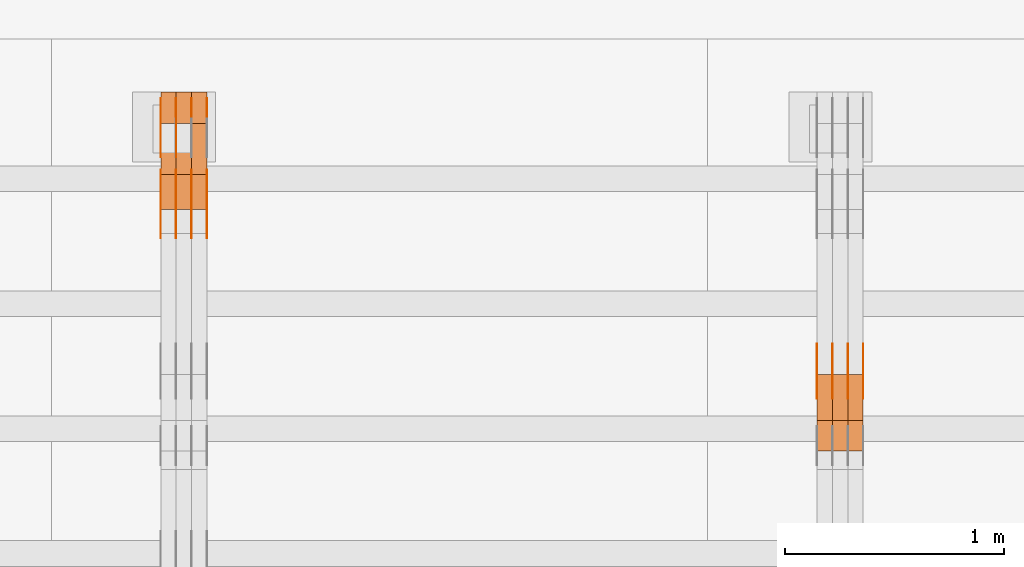
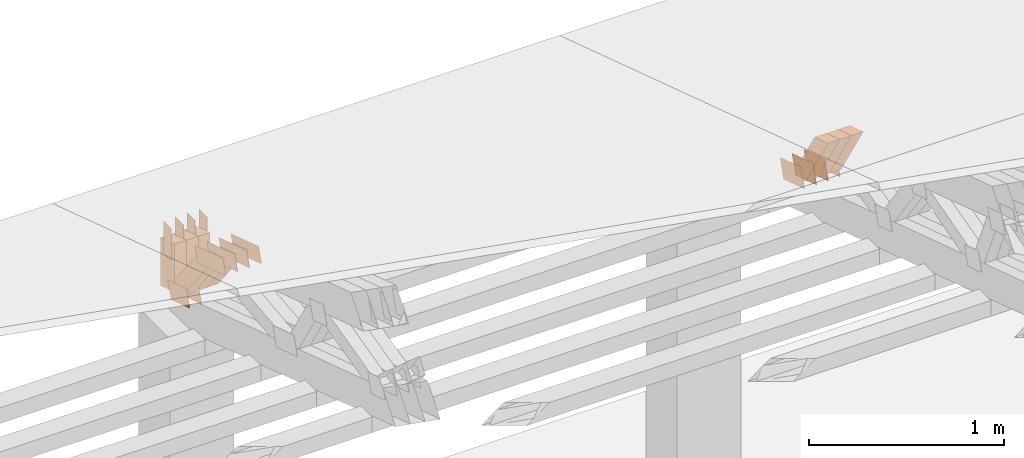
# One storey, part 238 of 385: 29 proxies.
"""IFC2X3 building model written with IfcOpenShell, lengths in millimetres."""

import ifcopenshell
import ifcopenshell.guid

model = None  # the IFC model being written
_history = None  # IfcOwnerHistory: only IFC2X3 demands one
_inside = {}  # id of a spatial element -> (the spatial element, [elements in it])
_under = {}  # id of a project, library or spatial element -> (it, [spatial elements below it])
_declared = {}  # id of a project -> (the project, [libraries it declares])
_typed = {}  # id of a type object -> (the type object, [elements of that type])
_made_of = {}  # id of a material, layer set ... -> (it, [elements and type objects made of it])


def new_model(schema):
    """Start an empty IFC model of exactly this schema.

    Asked for "IFC4X3", IfcOpenShell would pick the latest addendum, in which some entities
    have other attributes; the version numbers below select the first issue.
    IFC2X3 requires an IfcOwnerHistory on every rooted entity: one is made here for all.
    """
    global model, _history
    if schema == "IFC4X3":
        model = ifcopenshell.file(schema_version=(4, 3, 0, 0))
    else:
        model = ifcopenshell.file(schema=schema)
    _inside.clear()
    _under.clear()
    _declared.clear()
    _typed.clear()
    _made_of.clear()
    _history = None
    if model.schema == "IFC2X3":
        org = make("IfcOrganization", Name="unknown")
        user = make(
            "IfcPersonAndOrganization",
            ThePerson=make("IfcPerson", FamilyName="unknown"),
            TheOrganization=org,
        )
        app = make(
            "IfcApplication",
            ApplicationDeveloper=org,
            Version="unknown",
            ApplicationFullName="unknown",
            ApplicationIdentifier="unknown",
        )
        _history = make(
            "IfcOwnerHistory",
            OwningUser=user,
            OwningApplication=app,
            ChangeAction="ADDED",
            CreationDate=0,
        )
    return model


def make(cls, **values):
    """One entity of the class cls with the attributes given. An attribute that is None is left unset."""
    return model.create_entity(
        cls, **{name: value for name, value in values.items() if value is not None}
    )


def entity(cls, *values):
    """Any entity or typed value of the class cls, its attributes in the order of the schema. None: left unset."""
    e = model.create_entity(cls)
    for i, value in enumerate(values):
        if value is not None:
            e[i] = value
    return e


def rooted(cls, **values):
    """An entity with a GlobalId (a new one), such as an element, a storey or a relation."""
    return make(cls, GlobalId=ifcopenshell.guid.new(), OwnerHistory=_history, **values)


def si_unit(unit_type, name, prefix=None):
    """IfcSIUnit, for example si_unit("LENGTHUNIT", "METRE", prefix="MILLI")."""
    return make("IfcSIUnit", UnitType=unit_type, Prefix=prefix, Name=name)


def converted_unit(unit_type, name, factor, base, dimensions=None, offset=None):
    """IfcConversionBasedUnit, such as the inch: factor (a typed value) times the base unit."""
    return make(
        "IfcConversionBasedUnit"
        if offset is None
        else "IfcConversionBasedUnitWithOffset",
        ConversionOffset=offset,
        Dimensions=None
        if dimensions is None
        else entity("IfcDimensionalExponents", *dimensions),
        UnitType=unit_type,
        Name=name,
        ConversionFactor=make(
            "IfcMeasureWithUnit", ValueComponent=factor, UnitComponent=base
        ),
    )


def derived_unit(unit_type, elements):
    """IfcDerivedUnit: a product of units, each with its exponent."""
    return make(
        "IfcDerivedUnit",
        Elements=[
            make("IfcDerivedUnitElement", Unit=unit, Exponent=power)
            for unit, power in elements
        ],
        UnitType=unit_type,
    )


def assignment(units):
    """IfcUnitAssignment: the units of a project."""
    return None if units is None else make("IfcUnitAssignment", Units=units)


def point(xyz):
    """IfcCartesianPoint."""
    return None if xyz is None else make("IfcCartesianPoint", Coordinates=xyz)


def direction(xyz):
    """IfcDirection."""
    return None if xyz is None else make("IfcDirection", DirectionRatios=xyz)


def frame(location, z_axis=None, x_axis=None):
    """IfcAxis2Placement3D, a coordinate frame: its origin and axes. An axis left out is left unset."""
    return make(
        "IfcAxis2Placement3D",
        Location=point(location),
        Axis=direction(z_axis),
        RefDirection=direction(x_axis),
    )


def frame_2d(location, x_axis=None):
    """IfcAxis2Placement2D, a coordinate frame in the plane: its origin and x axis."""
    return make(
        "IfcAxis2Placement2D", Location=point(location), RefDirection=direction(x_axis)
    )


def origin():
    """The frame at (0, 0, 0) with its axes left unset."""
    return frame((0.0, 0.0, 0.0))


def place(relative_to, where):
    """IfcLocalPlacement: puts the frame where relative to a parent placement (None: the world)."""
    return make(
        "IfcLocalPlacement", PlacementRelTo=relative_to, RelativePlacement=where
    )


def context(
    kind, dimensions, precision=None, world=None, true_north=None, identifier=None
):
    """IfcGeometricRepresentationContext, for example the 3D "Model" context."""
    return make(
        "IfcGeometricRepresentationContext",
        ContextIdentifier=identifier,
        ContextType=kind,
        CoordinateSpaceDimension=dimensions,
        Precision=precision,
        WorldCoordinateSystem=world,
        TrueNorth=true_north,
    )


def subcontext(parent, identifier, kind, view, scale=None):
    """IfcGeometricRepresentationSubContext, for example "Body" below "Model"."""
    return make(
        "IfcGeometricRepresentationSubContext",
        ContextIdentifier=identifier,
        ContextType=kind,
        ParentContext=parent,
        TargetScale=scale,
        TargetView=view,
    )


def project(units=None, contexts=None):
    """IfcProject with its units and contexts."""
    return rooted(
        "IfcProject",
        Name="project",
        RepresentationContexts=contexts,
        UnitsInContext=assignment(units),
    )


def spatial(cls, under=None, at=None, **own):
    """A site, building, storey or space (cls), placed at a placement, below another one or the project."""
    s = rooted(cls, ObjectPlacement=at, **own)
    if under is not None:
        _under.setdefault(under.id(), (under, []))[1].append(s)
    return s


def polyline(points):
    """IfcPolyline through the points."""
    return make("IfcPolyline", Points=[point(p) for p in points])


def profile(cls, at=None, kind="AREA", **sizes):
    """A parametric profile (cls). Its sizes go by their IFC names, for example OverallWidth=200.0."""
    return make(cls, ProfileType=kind, Position=at, **sizes)


def rectangle(**sizes):
    """IfcRectangleProfileDef."""
    return profile("IfcRectangleProfileDef", **sizes)


def outline(outer, holes=None, kind="AREA"):
    """IfcArbitraryClosedProfileDef: a profile drawn as a closed curve; with holes, ...WithVoids."""
    if holes is None:
        return make("IfcArbitraryClosedProfileDef", ProfileType=kind, OuterCurve=outer)
    return make(
        "IfcArbitraryProfileDefWithVoids",
        ProfileType=kind,
        OuterCurve=outer,
        InnerCurves=holes,
    )


def extrude(swept, where, along, depth):
    """IfcExtrudedAreaSolid: the profile swept, set in the frame where, extruded along a direction by depth."""
    return make(
        "IfcExtrudedAreaSolid",
        SweptArea=swept,
        Position=where,
        ExtrudedDirection=direction(along),
        Depth=depth,
    )


def shape(context_of_items, identifier, shape_type, items):
    """IfcShapeRepresentation: the items that make up one representation, for example the "Body"."""
    return make(
        "IfcShapeRepresentation",
        ContextOfItems=context_of_items,
        RepresentationIdentifier=identifier,
        RepresentationType=shape_type,
        Items=items,
    )


def source(mapping_origin, context_of_items, identifier, shape_type, items):
    """IfcRepresentationMap: a shape defined once, which mapped items show again and again."""
    return make(
        "IfcRepresentationMap",
        MappingOrigin=mapping_origin,
        MappedRepresentation=shape(context_of_items, identifier, shape_type, items),
    )


def transform(
    local_origin,
    x_axis=None,
    y_axis=None,
    z_axis=None,
    scale=None,
    scale2=None,
    scale3=None,
    uniform=True,
):
    """IfcCartesianTransformationOperator3D, or its non-uniform kind. x_axis, y_axis, z_axis: its Axis1, 2, 3."""
    if uniform:
        return make(
            "IfcCartesianTransformationOperator3D",
            Axis1=direction(x_axis),
            Axis2=direction(y_axis),
            LocalOrigin=point(local_origin),
            Scale=scale,
            Axis3=direction(z_axis),
        )
    return make(
        "IfcCartesianTransformationOperator3DnonUniform",
        Axis1=direction(x_axis),
        Axis2=direction(y_axis),
        LocalOrigin=point(local_origin),
        Scale=scale,
        Axis3=direction(z_axis),
        Scale2=scale2,
        Scale3=scale3,
    )


def mapped(mapping_source, mapping_target):
    """IfcMappedItem: shows the shape of a source again, moved by a transform."""
    return make(
        "IfcMappedItem", MappingSource=mapping_source, MappingTarget=mapping_target
    )


def material(Name=None, Category=None):
    """IfcMaterial."""
    return make("IfcMaterial", Name=Name, Category=Category)


def made_of(thing, what):
    """Note that an element or type object is made of a material, layer set ...; save() writes the relation."""
    if what is not None:
        _made_of.setdefault(what.id(), (what, []))[1].append(thing)
    return thing


def type_object(cls, material=None, **own):
    """A type object (cls), such as IfcWallType, which elements share."""
    return made_of(rooted(cls, **own), material)


def type_shapes(of_type, sources):
    """Give a type object the sources (RepresentationMaps) that its elements show as mapped items."""
    of_type.RepresentationMaps = sources


def element(
    cls,
    number,
    at=None,
    inside=None,
    cuts=None,
    type_object=None,
    material=None,
    context=None,
    identifier="Body",
    shape_type=None,
    held_by="IfcProductDefinitionShape",
    body=None,
    shapes=None,
    **own,
):
    """One element of the class cls, such as IfcWall. Its Tag is "e" and its number.

    at: its placement. inside: the storey or other place that contains it. cuts: it is an
    opening in that element (IfcRelVoidsElement). A single representation is given by context,
    identifier, shape_type and body (its items); several are given by shapes. held_by: the class
    of the entity that holds the representations. save() writes the other relations.
    """
    e = rooted(cls, Tag="e%d" % number, ObjectPlacement=at, **own)
    if body is not None:
        shapes = [shape(context, identifier, shape_type, body)]
    if shapes is not None:
        e.Representation = make(held_by, Representations=shapes)
    if inside is not None:
        _inside.setdefault(inside.id(), (inside, []))[1].append(e)
    if cuts is not None:
        rooted(
            "IfcRelVoidsElement", RelatingBuildingElement=cuts, RelatedOpeningElement=e
        )
    if type_object is not None:
        _typed.setdefault(type_object.id(), (type_object, []))[1].append(e)
    return made_of(e, material)


def aggregate(whole, parts):
    """IfcRelAggregates: a whole, such as a stair, and the parts it consists of."""
    return rooted("IfcRelAggregates", RelatingObject=whole, RelatedObjects=parts)


def save(model, path):
    """Write the relations noted so far, then the file.

    IfcRelAggregates (storeys below a building ...), IfcRelContainedInSpatialStructure (elements
    in a storey), IfcRelDefinesByType, IfcRelAssociatesMaterial and IfcRelDeclares: one each for
    every whole, place, type object, material and project.
    """
    for whole, parts in _under.values():
        aggregate(whole, parts)
    for where, things in _inside.values():
        rooted(
            "IfcRelContainedInSpatialStructure",
            RelatedElements=things,
            RelatingStructure=where,
        )
    for kind, things in _typed.values():
        rooted("IfcRelDefinesByType", RelatedObjects=things, RelatingType=kind)
    for what, things in _made_of.values():
        rooted("IfcRelAssociatesMaterial", RelatedObjects=things, RelatingMaterial=what)
    for by, libraries in _declared.values():
        rooted("IfcRelDeclares", RelatingContext=by, RelatedDefinitions=libraries)
    model.write(path)


model = new_model("IFC2X3")

# Units and contexts
model_context = context("Model", 3, precision=0.01, world=origin(), true_north=direction((6.12303176911189e-17, 1.0)))
body_context = subcontext(model_context, "Body", "Model", "MODEL_VIEW")
ifc_project = project(units=[si_unit("LENGTHUNIT", "METRE", prefix="MILLI"), si_unit("AREAUNIT", "SQUARE_METRE"), si_unit("VOLUMEUNIT", "CUBIC_METRE"), converted_unit("PLANEANGLEUNIT", "DEGREE", entity("IfcRatioMeasure", 0.0174532925199433), si_unit("PLANEANGLEUNIT", "RADIAN"), dimensions=[0, 0, 0, 0, 0, 0, 0]), si_unit("MASSUNIT", "GRAM", prefix="KILO"), derived_unit("MASSDENSITYUNIT", [(si_unit("MASSUNIT", "GRAM", prefix="KILO"), 1), (si_unit("LENGTHUNIT", "METRE"), -3)]), si_unit("TIMEUNIT", "SECOND"), si_unit("FREQUENCYUNIT", "HERTZ"), si_unit("THERMODYNAMICTEMPERATUREUNIT", "DEGREE_CELSIUS"), derived_unit("THERMALTRANSMITTANCEUNIT", [(si_unit("MASSUNIT", "GRAM", prefix="KILO"), 1), (si_unit("THERMODYNAMICTEMPERATUREUNIT", "KELVIN"), -1), (si_unit("TIMEUNIT", "SECOND"), -3)]), derived_unit("VOLUMETRICFLOWRATEUNIT", [(si_unit("LENGTHUNIT", "METRE"), 3), (si_unit("TIMEUNIT", "SECOND"), -1)]), si_unit("ELECTRICCURRENTUNIT", "AMPERE"), si_unit("ELECTRICVOLTAGEUNIT", "VOLT"), si_unit("POWERUNIT", "WATT"), si_unit("FORCEUNIT", "NEWTON", prefix="KILO"), si_unit("ILLUMINANCEUNIT", "LUX"), si_unit("LUMINOUSFLUXUNIT", "LUMEN"), si_unit("LUMINOUSINTENSITYUNIT", "CANDELA"), derived_unit("USERDEFINED", [(si_unit("MASSUNIT", "GRAM", prefix="KILO"), -1), (si_unit("LENGTHUNIT", "METRE"), -2), (si_unit("TIMEUNIT", "SECOND"), 3), (si_unit("LUMINOUSFLUXUNIT", "LUMEN"), 1)]), derived_unit("LINEARVELOCITYUNIT", [(si_unit("LENGTHUNIT", "METRE"), 1), (si_unit("TIMEUNIT", "SECOND"), -1)]), si_unit("PRESSUREUNIT", "PASCAL"), derived_unit("USERDEFINED", [(si_unit("LENGTHUNIT", "METRE"), -2), (si_unit("MASSUNIT", "GRAM", prefix="KILO"), 1), (si_unit("TIMEUNIT", "SECOND"), -2)])], contexts=[model_context])

# Site, building, storey
site_placement = place(None, origin())
site = spatial("IfcSite", under=ifc_project, at=site_placement, CompositionType="ELEMENT")
building_placement = place(site_placement, origin())
building = spatial("IfcBuilding", under=site, at=building_placement, CompositionType="ELEMENT")
storey_placement = place(building_placement, origin())
storey = spatial("IfcBuildingStorey", under=building, at=storey_placement, Name="Default", CompositionType="ELEMENT", Elevation=0.0)

# Proxies
ifc_material_1 = material(Name="IfcSurfaceStyle #331820")
building_element_proxy_type_1 = type_object("IfcBuildingElementProxyType", PredefinedType="NOTDEFINED", material=ifc_material_1)
shared_shape_1 = source(origin(), body_context, "Body", "SweptSolid", [
    extrude(outline(polyline([(-112.50003853564, -60.0000121429077), (112.50002982902, -60.0000121429077), (112.500043250865, 60.0000121429077), (-112.500034544245, 60.0000121429077), (-112.50003853564, -60.0000121429077)])), frame((112.500056021398, 60.0000121429077, 0.0), z_axis=(0.0, 0.0, 1.0), x_axis=(-1.0, 0.0, 0.0)), (0.0, 0.0, 1.0), 1.3),
])
type_shapes(building_element_proxy_type_1, [shared_shape_1])
proxy_1_placement = place(building_placement, frame((27386.3, 25310.2182710495, 430.675738123044), z_axis=(-1.0, 0.0, 0.0), x_axis=(0.0, -0.951056516295124, 0.309016994375039)))
element("IfcBuildingElementProxy", 1, at=proxy_1_placement, inside=storey, type_object=building_element_proxy_type_1, material=ifc_material_1, context=body_context, shape_type="MappedRepresentation", body=[
    mapped(shared_shape_1, transform((0.0, 0.0, 0.0), scale=1.0)),
])
ifc_material_2 = material(Name="IfcSurfaceStyle #331763")
building_element_proxy_type_2 = type_object("IfcBuildingElementProxyType", PredefinedType="NOTDEFINED", material=ifc_material_2)
shared_shape_2 = source(origin(), body_context, "Body", "SweptSolid", [
    extrude(outline(polyline([(-112.50003853564, -60.0000121429077), (112.50002982902, -60.0000121429077), (112.500043250865, 60.0000121429077), (-112.500034544245, 60.0000121429077), (-112.50003853564, -60.0000121429077)])), frame((112.500056021398, 60.0000121429077, 0.0), z_axis=(0.0, 0.0, 1.0), x_axis=(-1.0, 0.0, 0.0)), (0.0, 0.0, 1.0), 1.3),
])
type_shapes(building_element_proxy_type_2, [shared_shape_2])
proxy_2_placement = place(building_placement, frame((27315.0, 25310.2182710495, 430.675738123044), z_axis=(-1.0, 0.0, 0.0), x_axis=(0.0, -0.951056516295124, 0.309016994375039)))
element("IfcBuildingElementProxy", 2, at=proxy_2_placement, inside=storey, type_object=building_element_proxy_type_2, material=ifc_material_2, context=body_context, shape_type="MappedRepresentation", body=[
    mapped(shared_shape_2, transform((0.0, 0.0, 0.0), scale=1.0)),
])
ifc_material_3 = material(Name="IfcSurfaceStyle #331706")
building_element_proxy_type_3 = type_object("IfcBuildingElementProxyType", PredefinedType="NOTDEFINED", material=ifc_material_3)
shared_shape_3 = source(origin(), body_context, "Body", "SweptSolid", [
    extrude(outline(polyline([(-112.50003853564, -60.0000121429077), (112.50002982902, -60.0000121429077), (112.500043250865, 60.0000121429077), (-112.500034544245, 60.0000121429077), (-112.50003853564, -60.0000121429077)])), frame((112.500056021398, 60.0000121429077, 0.0), z_axis=(0.0, 0.0, 1.0), x_axis=(-1.0, 0.0, 0.0)), (0.0, 0.0, 1.0), 1.3),
])
type_shapes(building_element_proxy_type_3, [shared_shape_3])
proxy_3_placement = place(building_placement, frame((27316.3, 25310.2182710495, 430.675738123044), z_axis=(-1.0, 0.0, 0.0), x_axis=(0.0, -0.951056516295124, 0.309016994375039)))
element("IfcBuildingElementProxy", 3, at=proxy_3_placement, inside=storey, type_object=building_element_proxy_type_3, material=ifc_material_3, context=body_context, shape_type="MappedRepresentation", body=[
    mapped(shared_shape_3, transform((0.0, 0.0, 0.0), scale=1.0)),
])
ifc_material_4 = material(Name="IfcSurfaceStyle #331649")
building_element_proxy_type_4 = type_object("IfcBuildingElementProxyType", PredefinedType="NOTDEFINED", material=ifc_material_4)
shared_shape_4 = source(origin(), body_context, "Body", "SweptSolid", [
    extrude(outline(polyline([(-112.50003853564, -60.0000121429077), (112.50002982902, -60.0000121429077), (112.500043250865, 60.0000121429077), (-112.500034544245, 60.0000121429077), (-112.50003853564, -60.0000121429077)])), frame((112.500056021398, 60.0000121429077, 0.0), z_axis=(0.0, 0.0, 1.0), x_axis=(-1.0, 0.0, 0.0)), (0.0, 0.0, 1.0), 1.29999999999998),
])
type_shapes(building_element_proxy_type_4, [shared_shape_4])
proxy_4_placement = place(building_placement, frame((27245.0, 25310.2182710495, 430.675738123044), z_axis=(-1.0, 0.0, 0.0), x_axis=(0.0, -0.951056516295124, 0.309016994375039)))
element("IfcBuildingElementProxy", 4, at=proxy_4_placement, inside=storey, type_object=building_element_proxy_type_4, material=ifc_material_4, context=body_context, shape_type="MappedRepresentation", body=[
    mapped(shared_shape_4, transform((0.0, 0.0, 0.0), scale=1.0)),
])
ifc_material_5 = material(Name="IfcSurfaceStyle #331592")
building_element_proxy_type_5 = type_object("IfcBuildingElementProxyType", PredefinedType="NOTDEFINED", material=ifc_material_5)
shared_shape_5 = source(origin(), body_context, "Body", "SweptSolid", [
    extrude(outline(polyline([(-112.50003853564, -60.0000121429077), (112.50002982902, -60.0000121429077), (112.500043250865, 60.0000121429077), (-112.500034544245, 60.0000121429077), (-112.50003853564, -60.0000121429077)])), frame((112.500056021398, 60.0000121429077, 0.0), z_axis=(0.0, 0.0, 1.0), x_axis=(-1.0, 0.0, 0.0)), (0.0, 0.0, 1.0), 1.29999999999998),
])
type_shapes(building_element_proxy_type_5, [shared_shape_5])
proxy_5_placement = place(building_placement, frame((27246.3, 25310.2182710495, 430.675738123044), z_axis=(-1.0, 0.0, 0.0), x_axis=(0.0, -0.951056516295124, 0.309016994375039)))
element("IfcBuildingElementProxy", 5, at=proxy_5_placement, inside=storey, type_object=building_element_proxy_type_5, material=ifc_material_5, context=body_context, shape_type="MappedRepresentation", body=[
    mapped(shared_shape_5, transform((0.0, 0.0, 0.0), scale=1.0)),
])
ifc_material_6 = material(Name="IfcSurfaceStyle #331535")
building_element_proxy_type_6 = type_object("IfcBuildingElementProxyType", PredefinedType="NOTDEFINED", material=ifc_material_6)
shared_shape_6 = source(origin(), body_context, "Body", "SweptSolid", [
    extrude(outline(polyline([(-112.50003853564, -60.0000121429077), (112.50002982902, -60.0000121429077), (112.500043250865, 60.0000121429077), (-112.500034544245, 60.0000121429077), (-112.50003853564, -60.0000121429077)])), frame((112.500056021398, 60.0000121429077, 0.0), z_axis=(0.0, 0.0, 1.0), x_axis=(-1.0, 0.0, 0.0)), (0.0, 0.0, 1.0), 1.29999999999999),
])
type_shapes(building_element_proxy_type_6, [shared_shape_6])
proxy_6_placement = place(building_placement, frame((27175.0, 25310.2182710495, 430.675738123044), z_axis=(-1.0, 0.0, 0.0), x_axis=(0.0, -0.951056516295124, 0.309016994375039)))
element("IfcBuildingElementProxy", 6, at=proxy_6_placement, inside=storey, type_object=building_element_proxy_type_6, material=ifc_material_6, context=body_context, shape_type="MappedRepresentation", body=[
    mapped(shared_shape_6, transform((0.0, 0.0, 0.0), scale=1.0)),
])
ifc_material_7 = material(Name="IfcSurfaceStyle #319778")
building_element_proxy_type_7 = type_object("IfcBuildingElementProxyType", Name="T1-W31 319776", PredefinedType="NOTDEFINED", material=ifc_material_7)
shared_shape_7 = source(origin(), body_context, "Body", "SweptSolid", [
    extrude(outline(polyline([(-201.245318299844, -47.5000121670808), (204.413774229459, -47.5000121670808), (182.034306640891, 5.35692244583164e-05), (126.70380769348, 47.4999853824686), (-311.906570263987, 47.4999853824686), (-201.245318299844, -47.5000121670808)])), frame((204.413774229459, 47.5002684334588, 0.0), z_axis=(0.0, 0.0, 1.0), x_axis=(-1.0, 0.0, 0.0)), (0.0, 0.0, 1.0), 70.0),
])
type_shapes(building_element_proxy_type_7, [shared_shape_7])
proxy_7_placement = place(building_placement, frame((27385.0, 25127.5652647985, 487.27008059185), z_axis=(-1.0, 0.0, 0.0), x_axis=(0.0, -0.520333970303023, 0.853962855953755)))
element("IfcBuildingElementProxy", 7, at=proxy_7_placement, inside=storey, type_object=building_element_proxy_type_7, material=ifc_material_7, Name="T1-W31", context=body_context, shape_type="MappedRepresentation", body=[
    mapped(shared_shape_7, transform((0.0, 0.0, 0.0), scale=1.0)),
])
ifc_material_8 = material(Name="IfcSurfaceStyle #319712")
building_element_proxy_type_8 = type_object("IfcBuildingElementProxyType", Name="T1-W31 319710", PredefinedType="NOTDEFINED", material=ifc_material_8)
shared_shape_8 = source(origin(), body_context, "Body", "SweptSolid", [
    extrude(outline(polyline([(-201.245318299844, -47.5000121670808), (204.413774229459, -47.5000121670808), (182.034306640891, 5.35692244583164e-05), (126.70380769348, 47.4999853824686), (-311.906570263987, 47.4999853824686), (-201.245318299844, -47.5000121670808)])), frame((204.413774229459, 47.5002684334588, 0.0), z_axis=(0.0, 0.0, 1.0), x_axis=(-1.0, 0.0, 0.0)), (0.0, 0.0, 1.0), 70.0),
])
type_shapes(building_element_proxy_type_8, [shared_shape_8])
proxy_8_placement = place(building_placement, frame((27315.0, 25127.5652647985, 487.27008059185), z_axis=(-1.0, 0.0, 0.0), x_axis=(0.0, -0.520333970303023, 0.853962855953755)))
element("IfcBuildingElementProxy", 8, at=proxy_8_placement, inside=storey, type_object=building_element_proxy_type_8, material=ifc_material_8, Name="T1-W31", context=body_context, shape_type="MappedRepresentation", body=[
    mapped(shared_shape_8, transform((0.0, 0.0, 0.0), scale=1.0)),
])
ifc_material_9 = material(Name="IfcSurfaceStyle #319646")
building_element_proxy_type_9 = type_object("IfcBuildingElementProxyType", Name="T1-W31 319644", PredefinedType="NOTDEFINED", material=ifc_material_9)
shared_shape_9 = source(origin(), body_context, "Body", "SweptSolid", [
    extrude(outline(polyline([(-201.245318299844, -47.5000121670808), (204.413774229459, -47.5000121670808), (182.034306640891, 5.35692244583164e-05), (126.70380769348, 47.4999853824686), (-311.906570263987, 47.4999853824686), (-201.245318299844, -47.5000121670808)])), frame((204.413774229459, 47.5002684334588, 0.0), z_axis=(0.0, 0.0, 1.0), x_axis=(-1.0, 0.0, 0.0)), (0.0, 0.0, 1.0), 70.0),
])
type_shapes(building_element_proxy_type_9, [shared_shape_9])
proxy_9_placement = place(building_placement, frame((27245.0, 25127.5652647985, 487.27008059185), z_axis=(-1.0, 0.0, 0.0), x_axis=(0.0, -0.520333970303023, 0.853962855953755)))
element("IfcBuildingElementProxy", 9, at=proxy_9_placement, inside=storey, type_object=building_element_proxy_type_9, material=ifc_material_9, Name="T1-W31", context=body_context, shape_type="MappedRepresentation", body=[
    mapped(shared_shape_9, transform((0.0, 0.0, 0.0), scale=1.0)),
])
ifc_material_10 = material(Name="IfcSurfaceStyle #309130")
building_element_proxy_type_10 = type_object("IfcBuildingElementProxyType", PredefinedType="NOTDEFINED", material=ifc_material_10)
shared_shape_10 = source(origin(), body_context, "Body", "SweptSolid", [
    extrude(outline(polyline([(-100.000024997547, -54.0000105875654), (100.000088940899, -54.0000105875654), (99.9999100805868, 54.0000105875654), (-99.9999740239394, 54.0000105875654), (-100.000024997547, -54.0000105875654)])), frame((100.000088940899, 54.0000474633838, 0.0), z_axis=(0.0, 0.0, 1.0), x_axis=(-1.0, 0.0, 0.0)), (0.0, 0.0, 1.0), 1.29999999999998),
])
type_shapes(building_element_proxy_type_10, [shared_shape_10])
proxy_10_placement = place(building_placement, frame((24246.3, 26390.6212638563, 73.3227520411355), z_axis=(-1.0, 0.0, 0.0), x_axis=(0.0, -0.951056516295124, 0.309016994375039)))
element("IfcBuildingElementProxy", 10, at=proxy_10_placement, inside=storey, type_object=building_element_proxy_type_10, material=ifc_material_10, context=body_context, shape_type="MappedRepresentation", body=[
    mapped(shared_shape_10, transform((0.0, 0.0, 0.0), scale=1.0)),
])
ifc_material_11 = material(Name="IfcSurfaceStyle #309073")
building_element_proxy_type_11 = type_object("IfcBuildingElementProxyType", PredefinedType="NOTDEFINED", material=ifc_material_11)
shared_shape_11 = source(origin(), body_context, "Body", "SweptSolid", [
    extrude(outline(polyline([(-100.000024997547, -54.0000105875654), (100.000088940899, -54.0000105875654), (99.9999100805868, 54.0000105875654), (-99.9999740239394, 54.0000105875654), (-100.000024997547, -54.0000105875654)])), frame((100.000088940899, 54.0000474633838, 0.0), z_axis=(0.0, 0.0, 1.0), x_axis=(-1.0, 0.0, 0.0)), (0.0, 0.0, 1.0), 1.29999999999999),
])
type_shapes(building_element_proxy_type_11, [shared_shape_11])
proxy_11_placement = place(building_placement, frame((24175.0, 26390.6212638563, 73.3227520411355), z_axis=(-1.0, 0.0, 0.0), x_axis=(0.0, -0.951056516295124, 0.309016994375039)))
element("IfcBuildingElementProxy", 11, at=proxy_11_placement, inside=storey, type_object=building_element_proxy_type_11, material=ifc_material_11, context=body_context, shape_type="MappedRepresentation", body=[
    mapped(shared_shape_11, transform((0.0, 0.0, 0.0), scale=1.0)),
])
ifc_material_12 = material(Name="IfcSurfaceStyle #296704")
building_element_proxy_type_12 = type_object("IfcBuildingElementProxyType", PredefinedType="NOTDEFINED", material=ifc_material_12)
shared_shape_12 = source(origin(), body_context, "Body", "SweptSolid", [
    extrude(outline(polyline([(-149.999901061401, -48.0000057587028), (150.000035297123, -48.0000057587028), (149.999910491851, 48.0000057587028), (-150.000044727574, 48.0000057587028), (-149.999901061401, -48.0000057587028)])), frame((150.000035297123, 48.0000632585775, 0.0), z_axis=(0.0, 0.0, 1.0), x_axis=(-1.0, 0.0, 0.0)), (0.0, 0.0, 1.0), 1.29999999999999),
])
type_shapes(building_element_proxy_type_12, [shared_shape_12])
proxy_12_placement = place(building_placement, frame((24386.3, 26115.0176968219, 469.58296924555), z_axis=(-1.0, 0.0, 0.0), x_axis=(0.0, -0.951056516295154, 0.309016994374948)))
element("IfcBuildingElementProxy", 12, at=proxy_12_placement, inside=storey, type_object=building_element_proxy_type_12, material=ifc_material_12, context=body_context, shape_type="MappedRepresentation", body=[
    mapped(shared_shape_12, transform((0.0, 0.0, 0.0), scale=1.0)),
])
ifc_material_13 = material(Name="IfcSurfaceStyle #296647")
building_element_proxy_type_13 = type_object("IfcBuildingElementProxyType", PredefinedType="NOTDEFINED", material=ifc_material_13)
shared_shape_13 = source(origin(), body_context, "Body", "SweptSolid", [
    extrude(outline(polyline([(-149.999901061401, -48.0000057587028), (150.000035297123, -48.0000057587028), (149.999910491851, 48.0000057587028), (-150.000044727574, 48.0000057587028), (-149.999901061401, -48.0000057587028)])), frame((150.000035297123, 48.0000632585775, 0.0), z_axis=(0.0, 0.0, 1.0), x_axis=(-1.0, 0.0, 0.0)), (0.0, 0.0, 1.0), 1.29999999999999),
])
type_shapes(building_element_proxy_type_13, [shared_shape_13])
proxy_13_placement = place(building_placement, frame((24315.0, 26115.0176968219, 469.58296924555), z_axis=(-1.0, 0.0, 0.0), x_axis=(0.0, -0.951056516295154, 0.309016994374948)))
element("IfcBuildingElementProxy", 13, at=proxy_13_placement, inside=storey, type_object=building_element_proxy_type_13, material=ifc_material_13, context=body_context, shape_type="MappedRepresentation", body=[
    mapped(shared_shape_13, transform((0.0, 0.0, 0.0), scale=1.0)),
])
ifc_material_14 = material(Name="IfcSurfaceStyle #296590")
building_element_proxy_type_14 = type_object("IfcBuildingElementProxyType", PredefinedType="NOTDEFINED", material=ifc_material_14)
shared_shape_14 = source(origin(), body_context, "Body", "SweptSolid", [
    extrude(outline(polyline([(-149.999901061401, -48.0000057587028), (150.000035297123, -48.0000057587028), (149.999910491851, 48.0000057587028), (-150.000044727574, 48.0000057587028), (-149.999901061401, -48.0000057587028)])), frame((150.000035297123, 48.0000632585775, 0.0), z_axis=(0.0, 0.0, 1.0), x_axis=(-1.0, 0.0, 0.0)), (0.0, 0.0, 1.0), 1.29999999999999),
])
type_shapes(building_element_proxy_type_14, [shared_shape_14])
proxy_14_placement = place(building_placement, frame((24316.3, 26115.0176968219, 469.58296924555), z_axis=(-1.0, 0.0, 0.0), x_axis=(0.0, -0.951056516295154, 0.309016994374948)))
element("IfcBuildingElementProxy", 14, at=proxy_14_placement, inside=storey, type_object=building_element_proxy_type_14, material=ifc_material_14, context=body_context, shape_type="MappedRepresentation", body=[
    mapped(shared_shape_14, transform((0.0, 0.0, 0.0), scale=1.0)),
])
ifc_material_15 = material(Name="IfcSurfaceStyle #296533")
building_element_proxy_type_15 = type_object("IfcBuildingElementProxyType", PredefinedType="NOTDEFINED", material=ifc_material_15)
shared_shape_15 = source(origin(), body_context, "Body", "SweptSolid", [
    extrude(outline(polyline([(-149.999901061401, -48.0000057587028), (150.000035297123, -48.0000057587028), (149.999910491851, 48.0000057587028), (-150.000044727574, 48.0000057587028), (-149.999901061401, -48.0000057587028)])), frame((150.000035297123, 48.0000632585775, 0.0), z_axis=(0.0, 0.0, 1.0), x_axis=(-1.0, 0.0, 0.0)), (0.0, 0.0, 1.0), 1.29999999999998),
])
type_shapes(building_element_proxy_type_15, [shared_shape_15])
proxy_15_placement = place(building_placement, frame((24245.0, 26115.0176968219, 469.58296924555), z_axis=(-1.0, 0.0, 0.0), x_axis=(0.0, -0.951056516295154, 0.309016994374948)))
element("IfcBuildingElementProxy", 15, at=proxy_15_placement, inside=storey, type_object=building_element_proxy_type_15, material=ifc_material_15, context=body_context, shape_type="MappedRepresentation", body=[
    mapped(shared_shape_15, transform((0.0, 0.0, 0.0), scale=1.0)),
])
ifc_material_16 = material(Name="IfcSurfaceStyle #296476")
building_element_proxy_type_16 = type_object("IfcBuildingElementProxyType", PredefinedType="NOTDEFINED", material=ifc_material_16)
shared_shape_16 = source(origin(), body_context, "Body", "SweptSolid", [
    extrude(outline(polyline([(-149.999901061401, -48.0000057587028), (150.000035297123, -48.0000057587028), (149.999910491851, 48.0000057587028), (-150.000044727574, 48.0000057587028), (-149.999901061401, -48.0000057587028)])), frame((150.000035297123, 48.0000632585775, 0.0), z_axis=(0.0, 0.0, 1.0), x_axis=(-1.0, 0.0, 0.0)), (0.0, 0.0, 1.0), 1.29999999999998),
])
type_shapes(building_element_proxy_type_16, [shared_shape_16])
proxy_16_placement = place(building_placement, frame((24246.3, 26115.0176968219, 469.58296924555), z_axis=(-1.0, 0.0, 0.0), x_axis=(0.0, -0.951056516295154, 0.309016994374948)))
element("IfcBuildingElementProxy", 16, at=proxy_16_placement, inside=storey, type_object=building_element_proxy_type_16, material=ifc_material_16, context=body_context, shape_type="MappedRepresentation", body=[
    mapped(shared_shape_16, transform((0.0, 0.0, 0.0), scale=1.0)),
])
ifc_material_17 = material(Name="IfcSurfaceStyle #296419")
building_element_proxy_type_17 = type_object("IfcBuildingElementProxyType", PredefinedType="NOTDEFINED", material=ifc_material_17)
shared_shape_17 = source(origin(), body_context, "Body", "SweptSolid", [
    extrude(outline(polyline([(-149.999901061401, -48.0000057587028), (150.000035297123, -48.0000057587028), (149.999910491851, 48.0000057587028), (-150.000044727574, 48.0000057587028), (-149.999901061401, -48.0000057587028)])), frame((150.000035297123, 48.0000632585775, 0.0), z_axis=(0.0, 0.0, 1.0), x_axis=(-1.0, 0.0, 0.0)), (0.0, 0.0, 1.0), 1.29999999999998),
])
type_shapes(building_element_proxy_type_17, [shared_shape_17])
proxy_17_placement = place(building_placement, frame((24175.0, 26115.0176968219, 469.58296924555), z_axis=(-1.0, 0.0, 0.0), x_axis=(0.0, -0.951056516295154, 0.309016994374948)))
element("IfcBuildingElementProxy", 17, at=proxy_17_placement, inside=storey, type_object=building_element_proxy_type_17, material=ifc_material_17, context=body_context, shape_type="MappedRepresentation", body=[
    mapped(shared_shape_17, transform((0.0, 0.0, 0.0), scale=1.0)),
])
ifc_material_18 = material(Name="IfcSurfaceStyle #296362")
building_element_proxy_type_18 = type_object("IfcBuildingElementProxyType", PredefinedType="NOTDEFINED", material=ifc_material_18)
shared_shape_18 = source(origin(), body_context, "Body", "SweptSolid", [
    extrude(rectangle(XDim=200.0, YDim=84.0000000000005, at=frame_2d((-2.1316282072803e-14, 1.06581410364015e-14), x_axis=(1.0, 0.0))), frame((100.0, 42.0, 0.0), z_axis=(0.0, 0.0, 1.0), x_axis=(-1.0, 0.0, 0.0)), (0.0, 0.0, 1.0), 1.3),
])
type_shapes(building_element_proxy_type_18, [shared_shape_18])
proxy_18_placement = place(building_placement, frame((24386.3, 26469.5000000002, 518.521545410156), z_axis=(-1.0, 0.0, 0.0), x_axis=(0.0, 0.0, -1.0)))
element("IfcBuildingElementProxy", 18, at=proxy_18_placement, inside=storey, type_object=building_element_proxy_type_18, material=ifc_material_18, context=body_context, shape_type="MappedRepresentation", body=[
    mapped(shared_shape_18, transform((0.0, 0.0, 0.0), scale=1.0)),
])
ifc_material_19 = material(Name="IfcSurfaceStyle #296305")
building_element_proxy_type_19 = type_object("IfcBuildingElementProxyType", PredefinedType="NOTDEFINED", material=ifc_material_19)
shared_shape_19 = source(origin(), body_context, "Body", "SweptSolid", [
    extrude(rectangle(XDim=200.0, YDim=84.0000000000005, at=frame_2d((-2.1316282072803e-14, 1.06581410364015e-14), x_axis=(1.0, 0.0))), frame((100.0, 42.0, 0.0), z_axis=(0.0, 0.0, 1.0), x_axis=(-1.0, 0.0, 0.0)), (0.0, 0.0, 1.0), 1.3),
])
type_shapes(building_element_proxy_type_19, [shared_shape_19])
proxy_19_placement = place(building_placement, frame((24315.0, 26469.5000000002, 518.521545410156), z_axis=(-1.0, 0.0, 0.0), x_axis=(0.0, 0.0, -1.0)))
element("IfcBuildingElementProxy", 19, at=proxy_19_placement, inside=storey, type_object=building_element_proxy_type_19, material=ifc_material_19, context=body_context, shape_type="MappedRepresentation", body=[
    mapped(shared_shape_19, transform((0.0, 0.0, 0.0), scale=1.0)),
])
ifc_material_20 = material(Name="IfcSurfaceStyle #296248")
building_element_proxy_type_20 = type_object("IfcBuildingElementProxyType", PredefinedType="NOTDEFINED", material=ifc_material_20)
shared_shape_20 = source(origin(), body_context, "Body", "SweptSolid", [
    extrude(rectangle(XDim=200.0, YDim=84.0000000000005, at=frame_2d((-2.1316282072803e-14, 1.06581410364015e-14), x_axis=(1.0, 0.0))), frame((100.0, 42.0, 0.0), z_axis=(0.0, 0.0, 1.0), x_axis=(-1.0, 0.0, 0.0)), (0.0, 0.0, 1.0), 1.3),
])
type_shapes(building_element_proxy_type_20, [shared_shape_20])
proxy_20_placement = place(building_placement, frame((24316.3, 26469.5000000002, 518.521545410156), z_axis=(-1.0, 0.0, 0.0), x_axis=(0.0, 0.0, -1.0)))
element("IfcBuildingElementProxy", 20, at=proxy_20_placement, inside=storey, type_object=building_element_proxy_type_20, material=ifc_material_20, context=body_context, shape_type="MappedRepresentation", body=[
    mapped(shared_shape_20, transform((0.0, 0.0, 0.0), scale=1.0)),
])
ifc_material_21 = material(Name="IfcSurfaceStyle #296191")
building_element_proxy_type_21 = type_object("IfcBuildingElementProxyType", PredefinedType="NOTDEFINED", material=ifc_material_21)
shared_shape_21 = source(origin(), body_context, "Body", "SweptSolid", [
    extrude(rectangle(XDim=200.0, YDim=84.0000000000005, at=frame_2d((-2.1316282072803e-14, 1.06581410364015e-14), x_axis=(1.0, 0.0))), frame((100.0, 42.0, 0.0), z_axis=(0.0, 0.0, 1.0), x_axis=(-1.0, 0.0, 0.0)), (0.0, 0.0, 1.0), 1.29999999999998),
])
type_shapes(building_element_proxy_type_21, [shared_shape_21])
proxy_21_placement = place(building_placement, frame((24245.0, 26469.5000000002, 518.521545410156), z_axis=(-1.0, 0.0, 0.0), x_axis=(0.0, 0.0, -1.0)))
element("IfcBuildingElementProxy", 21, at=proxy_21_placement, inside=storey, type_object=building_element_proxy_type_21, material=ifc_material_21, context=body_context, shape_type="MappedRepresentation", body=[
    mapped(shared_shape_21, transform((0.0, 0.0, 0.0), scale=1.0)),
])
ifc_material_22 = material(Name="IfcSurfaceStyle #296134")
building_element_proxy_type_22 = type_object("IfcBuildingElementProxyType", PredefinedType="NOTDEFINED", material=ifc_material_22)
shared_shape_22 = source(origin(), body_context, "Body", "SweptSolid", [
    extrude(rectangle(XDim=200.0, YDim=84.0000000000005, at=frame_2d((-2.1316282072803e-14, 1.06581410364015e-14), x_axis=(1.0, 0.0))), frame((100.0, 42.0, 0.0), z_axis=(0.0, 0.0, 1.0), x_axis=(-1.0, 0.0, 0.0)), (0.0, 0.0, 1.0), 1.29999999999998),
])
type_shapes(building_element_proxy_type_22, [shared_shape_22])
proxy_22_placement = place(building_placement, frame((24246.3, 26469.5000000002, 518.521545410156), z_axis=(-1.0, 0.0, 0.0), x_axis=(0.0, 0.0, -1.0)))
element("IfcBuildingElementProxy", 22, at=proxy_22_placement, inside=storey, type_object=building_element_proxy_type_22, material=ifc_material_22, context=body_context, shape_type="MappedRepresentation", body=[
    mapped(shared_shape_22, transform((0.0, 0.0, 0.0), scale=1.0)),
])
ifc_material_23 = material(Name="IfcSurfaceStyle #296077")
building_element_proxy_type_23 = type_object("IfcBuildingElementProxyType", PredefinedType="NOTDEFINED", material=ifc_material_23)
shared_shape_23 = source(origin(), body_context, "Body", "SweptSolid", [
    extrude(rectangle(XDim=200.0, YDim=84.0000000000005, at=frame_2d((-2.1316282072803e-14, 1.06581410364015e-14), x_axis=(1.0, 0.0))), frame((100.0, 42.0, 0.0), z_axis=(0.0, 0.0, 1.0), x_axis=(-1.0, 0.0, 0.0)), (0.0, 0.0, 1.0), 1.29999999999999),
])
type_shapes(building_element_proxy_type_23, [shared_shape_23])
proxy_23_placement = place(building_placement, frame((24175.0, 26469.5000000002, 518.521545410156), z_axis=(-1.0, 0.0, 0.0), x_axis=(0.0, 0.0, -1.0)))
element("IfcBuildingElementProxy", 23, at=proxy_23_placement, inside=storey, type_object=building_element_proxy_type_23, material=ifc_material_23, context=body_context, shape_type="MappedRepresentation", body=[
    mapped(shared_shape_23, transform((0.0, 0.0, 0.0), scale=1.0)),
])
ifc_material_24 = material(Name="IfcSurfaceStyle #284554")
building_element_proxy_type_24 = type_object("IfcBuildingElementProxyType", Name="T1-W21 284552", PredefinedType="NOTDEFINED", material=ifc_material_24)
shared_shape_24 = source(origin(), body_context, "Body", "SweptSolid", [
    extrude(outline(polyline([(-209.199362597501, -47.5000308982766), (168.813164734153, -47.5000308982766), (229.900717355638, -2.18385470334148e-05), (159.828709317766, 47.5000418175501), (-349.343228810055, 47.5000418175502), (-209.199362597501, -47.5000308982766)])), frame((229.900720156071, 47.5000418175501, 0.0), z_axis=(0.0, 0.0, 1.0), x_axis=(-1.0, 0.0, 0.0)), (0.0, 0.0, 1.0), 70.0),
])
type_shapes(building_element_proxy_type_24, [shared_shape_24])
proxy_24_placement = place(building_placement, frame((24385.0, 26317.5019908272, 112.518372832984), z_axis=(-1.0, 0.0, 0.0), x_axis=(0.0, -0.613839629272042, 0.789430750310097)))
element("IfcBuildingElementProxy", 24, at=proxy_24_placement, inside=storey, type_object=building_element_proxy_type_24, material=ifc_material_24, Name="T1-W21", context=body_context, shape_type="MappedRepresentation", body=[
    mapped(shared_shape_24, transform((0.0, 0.0, 0.0), scale=1.0)),
])
ifc_material_25 = material(Name="IfcSurfaceStyle #284488")
building_element_proxy_type_25 = type_object("IfcBuildingElementProxyType", Name="T1-W21 284486", PredefinedType="NOTDEFINED", material=ifc_material_25)
shared_shape_25 = source(origin(), body_context, "Body", "SweptSolid", [
    extrude(outline(polyline([(-209.199362597501, -47.5000308982766), (168.813164734153, -47.5000308982766), (229.900717355638, -2.18385470334148e-05), (159.828709317766, 47.5000418175501), (-349.343228810055, 47.5000418175502), (-209.199362597501, -47.5000308982766)])), frame((229.900720156071, 47.5000418175501, 0.0), z_axis=(0.0, 0.0, 1.0), x_axis=(-1.0, 0.0, 0.0)), (0.0, 0.0, 1.0), 70.0),
])
type_shapes(building_element_proxy_type_25, [shared_shape_25])
proxy_25_placement = place(building_placement, frame((24315.0, 26317.5019908272, 112.518372832984), z_axis=(-1.0, 0.0, 0.0), x_axis=(0.0, -0.613839629272042, 0.789430750310097)))
element("IfcBuildingElementProxy", 25, at=proxy_25_placement, inside=storey, type_object=building_element_proxy_type_25, material=ifc_material_25, Name="T1-W21", context=body_context, shape_type="MappedRepresentation", body=[
    mapped(shared_shape_25, transform((0.0, 0.0, 0.0), scale=1.0)),
])
ifc_material_26 = material(Name="IfcSurfaceStyle #284422")
building_element_proxy_type_26 = type_object("IfcBuildingElementProxyType", Name="T1-W21 284420", PredefinedType="NOTDEFINED", material=ifc_material_26)
shared_shape_26 = source(origin(), body_context, "Body", "SweptSolid", [
    extrude(outline(polyline([(-209.199362597501, -47.5000308982766), (168.813164734153, -47.5000308982766), (229.900717355638, -2.18385470334148e-05), (159.828709317766, 47.5000418175501), (-349.343228810055, 47.5000418175502), (-209.199362597501, -47.5000308982766)])), frame((229.900720156071, 47.5000418175501, 0.0), z_axis=(0.0, 0.0, 1.0), x_axis=(-1.0, 0.0, 0.0)), (0.0, 0.0, 1.0), 70.0),
])
type_shapes(building_element_proxy_type_26, [shared_shape_26])
proxy_26_placement = place(building_placement, frame((24245.0, 26317.5019908272, 112.518372832984), z_axis=(-1.0, 0.0, 0.0), x_axis=(0.0, -0.613839629272042, 0.789430750310097)))
element("IfcBuildingElementProxy", 26, at=proxy_26_placement, inside=storey, type_object=building_element_proxy_type_26, material=ifc_material_26, Name="T1-W21", context=body_context, shape_type="MappedRepresentation", body=[
    mapped(shared_shape_26, transform((0.0, 0.0, 0.0), scale=1.0)),
])
ifc_material_27 = material(Name="IfcSurfaceStyle #283987")
building_element_proxy_type_27 = type_object("IfcBuildingElementProxyType", Name="T1-E2 283985", PredefinedType="NOTDEFINED", material=ifc_material_27)
shared_shape_27 = source(origin(), body_context, "Body", "SweptSolid", [
    extrude(outline(polyline([(-126.644535064697, -72.4999999999998), (173.757884979248, -72.4999999999998), (126.644542694092, 72.4999999999998), (-173.757892608642, 72.4999999999998), (-126.644535064697, -72.4999999999998)])), frame((173.757890653796, 72.5000000000002, 0.0), z_axis=(0.0, 0.0, 1.0), x_axis=(-1.0, 0.0, 0.0)), (0.0, 0.0, 1.0), 70.0),
])
type_shapes(building_element_proxy_type_27, [shared_shape_27])
proxy_27_placement = place(building_placement, frame((24385.0, 26500.0, 442.078222227283), z_axis=(-1.0, 0.0, 0.0), x_axis=(0.0, 0.0, -1.0)))
element("IfcBuildingElementProxy", 27, at=proxy_27_placement, inside=storey, type_object=building_element_proxy_type_27, material=ifc_material_27, Name="T1-E2", context=body_context, shape_type="MappedRepresentation", body=[
    mapped(shared_shape_27, transform((0.0, 0.0, 0.0), scale=1.0)),
])
ifc_material_28 = material(Name="IfcSurfaceStyle #283930")
building_element_proxy_type_28 = type_object("IfcBuildingElementProxyType", Name="T1-E2 283928", PredefinedType="NOTDEFINED", material=ifc_material_28)
shared_shape_28 = source(origin(), body_context, "Body", "SweptSolid", [
    extrude(outline(polyline([(-126.644535064697, -72.4999999999998), (173.757884979248, -72.4999999999998), (126.644542694092, 72.4999999999998), (-173.757892608642, 72.4999999999998), (-126.644535064697, -72.4999999999998)])), frame((173.757890653796, 72.5000000000002, 0.0), z_axis=(0.0, 0.0, 1.0), x_axis=(-1.0, 0.0, 0.0)), (0.0, 0.0, 1.0), 70.0),
])
type_shapes(building_element_proxy_type_28, [shared_shape_28])
proxy_28_placement = place(building_placement, frame((24315.0, 26500.0, 442.078222227283), z_axis=(-1.0, 0.0, 0.0), x_axis=(0.0, 0.0, -1.0)))
element("IfcBuildingElementProxy", 28, at=proxy_28_placement, inside=storey, type_object=building_element_proxy_type_28, material=ifc_material_28, Name="T1-E2", context=body_context, shape_type="MappedRepresentation", body=[
    mapped(shared_shape_28, transform((0.0, 0.0, 0.0), scale=1.0)),
])
ifc_material_29 = material(Name="IfcSurfaceStyle #283873")
building_element_proxy_type_29 = type_object("IfcBuildingElementProxyType", Name="T1-E2 283871", PredefinedType="NOTDEFINED", material=ifc_material_29)
shared_shape_29 = source(origin(), body_context, "Body", "SweptSolid", [
    extrude(outline(polyline([(-126.644535064697, -72.4999999999998), (173.757884979248, -72.4999999999998), (126.644542694092, 72.4999999999998), (-173.757892608642, 72.4999999999998), (-126.644535064697, -72.4999999999998)])), frame((173.757890653796, 72.5000000000002, 0.0), z_axis=(0.0, 0.0, 1.0), x_axis=(-1.0, 0.0, 0.0)), (0.0, 0.0, 1.0), 70.0),
])
type_shapes(building_element_proxy_type_29, [shared_shape_29])
proxy_29_placement = place(building_placement, frame((24245.0, 26500.0, 442.078222227283), z_axis=(-1.0, 0.0, 0.0), x_axis=(0.0, 0.0, -1.0)))
element("IfcBuildingElementProxy", 29, at=proxy_29_placement, inside=storey, type_object=building_element_proxy_type_29, material=ifc_material_29, Name="T1-E2", context=body_context, shape_type="MappedRepresentation", body=[
    mapped(shared_shape_29, transform((0.0, 0.0, 0.0), scale=1.0)),
])

save(model, "model.ifc")
